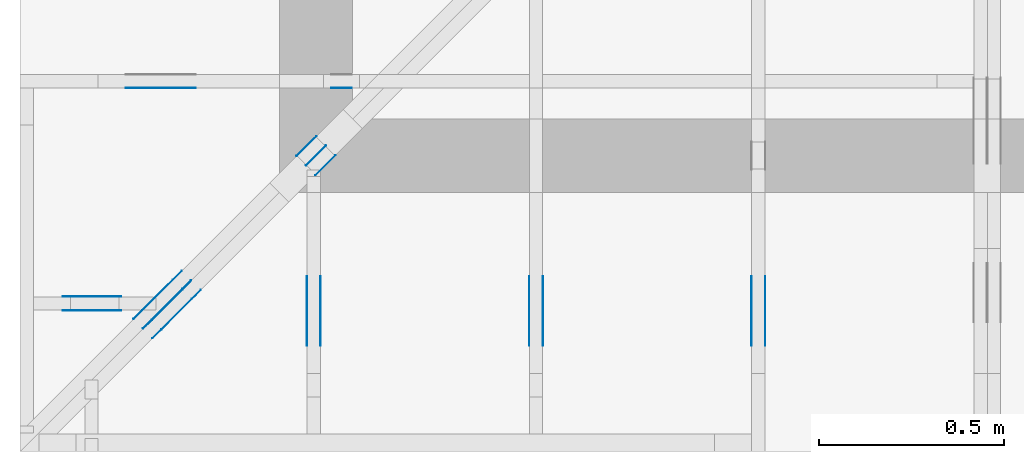
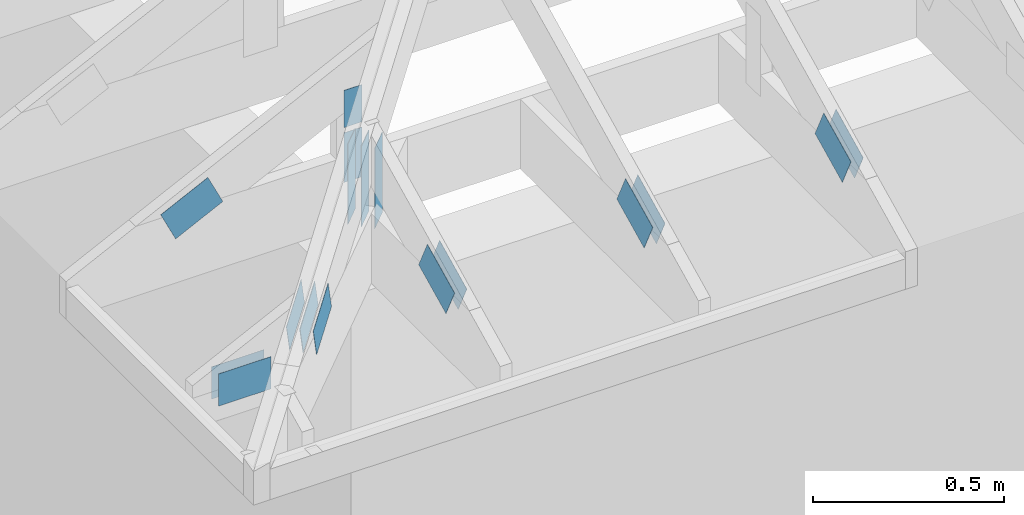
# One storey, part 55 of 159: 19 plates, 6 elements without a shape of their own.
"""IFC2X3 building model written with IfcOpenShell, lengths in millimetres."""

from ifc_helpers import new_model, si_unit, frame, origin, origin_with_axes, origin_2d, place, context, project, spatial, faceted_brep, element, aggregate, save


model = new_model("IFC2X3")

# Units and contexts
model_context = context("Model", 3, precision=1e-05, world=origin())
plan_context = context("Plan", 2, precision=1e-05, world=origin_2d())
ifc_project = project(units=[si_unit("LENGTHUNIT", "METRE", prefix="MILLI"), si_unit("AREAUNIT", "SQUARE_METRE"), si_unit("VOLUMEUNIT", "CUBIC_METRE"), si_unit("SOLIDANGLEUNIT", "STERADIAN"), si_unit("PLANEANGLEUNIT", "RADIAN"), si_unit("MASSUNIT", "GRAM"), si_unit("TIMEUNIT", "SECOND"), si_unit("THERMODYNAMICTEMPERATUREUNIT", "DEGREE_CELSIUS"), si_unit("LUMINOUSINTENSITYUNIT", "LUMEN")], contexts=[model_context, plan_context])

# Site, building, storey
site_placement = place(None, origin_with_axes())
site = spatial("IfcSite", under=ifc_project, at=site_placement, CompositionType="ELEMENT")
building_placement = place(site_placement, origin_with_axes())
building = spatial("IfcBuilding", under=site, at=building_placement, Name="Plan 1", CompositionType="ELEMENT")
storey_placement = place(building_placement, origin_with_axes())
storey = spatial("IfcBuildingStorey", under=building, at=storey_placement, Name="Etasje 1", CompositionType="ELEMENT", Elevation=0.0)

# Assembly, plates
assembly_1_placement = place(storey_placement, frame((-664.0000000000214, -317.99259857873943, 1.1021457184401395e-15), z_axis=(0.0, -1.0, 6.123031769111886e-17), x_axis=(1.0, 0.0, 0.0)))
assembly_1 = element("IfcElementAssembly", 1, at=assembly_1_placement, inside=storey, Name="S9 (106)", AssemblyPlace="FACTORY", PredefinedType="TRUSS")
plate_1_placement = place(assembly_1_placement, frame((237.78413391113284, 148.90464782714844, 0.0), z_axis=(0.0, 0.0, 1.0), x_axis=(-1.0, 1.2246063538223773e-16, 0.0)))
plate_1 = element("IfcPlate", 2, at=plate_1_placement, Name="GNT100S 103x159", context=model_context, shape_type="Brep", body=[
    faceted_brep([(159.0, 103.0, 1.0), (0.0, 103.0, 1.0), (2.842170943040401e-14, 0.0, 1.0), (159.0, 0.0, 1.0), (0.0, 103.0, 0.0), (159.0, 103.0, 1.9471241025775798e-14), (159.0, 2.842170943040401e-14, 1.9471241025775798e-14), (2.842170943040401e-14, 2.842170943040401e-14, 3.4805405954966126e-30), (159.00000085986846, 8.447997602500227e-14, 1.7883454204442307e-30), (159.00000085986846, 8.454120634269339e-14, 1.0), (8.59868492852911e-07, 1.1374806788135708e-13, 1.0), (8.59868492852911e-07, 1.1368683756366597e-13, 9.671333203439804e-39), (159.00000085986846, 103.00000000000011, 0.0), (159.00000085986846, 103.00000000000011, 1.0), (159.00000085986846, 1.1368683772161603e-13, 1.0), (159.00000085986846, 1.1368683772161603e-13, 0.0), (8.598684644312016e-07, 103.00000000000011, 0.0), (8.598684644312016e-07, 103.00000000000011, 1.0), (159.00000085986846, 103.0000000000001, 1.0), (159.00000085986846, 103.0000000000001, -7.888609052210118e-31), (8.59868492852911e-07, 1.1368683772161602e-13, 0.0), (8.598684929141413e-07, 1.1368683772161602e-13, 1.0), (8.598685055275868e-07, 103.00000000000011, 1.0), (8.598685054663564e-07, 103.00000000000011, -2.512595570956075e-30)], [[[0, 1, 2, 3]], [[4, 5, 6, 7]], [[8, 9, 10, 11]], [[12, 13, 14, 15]], [[16, 17, 18, 19]], [[20, 21, 22, 23]]]),
])
plate_2_placement = place(assembly_1_placement, frame((237.78413391113284, 148.90464782714844, -37.0), z_axis=(0.0, 0.0, 1.0), x_axis=(-1.0, 1.2246063538223773e-16, 0.0)))
plate_2 = element("IfcPlate", 3, at=plate_2_placement, Name="GNT100S 103x159", context=model_context, shape_type="Brep", body=[
    faceted_brep([(159.0, 103.0, 1.0), (0.0, 103.0, 1.0), (2.842170943040401e-14, 0.0, 1.0), (159.0, 0.0, 1.0), (0.0, 103.0, 0.0), (159.0, 103.0, 1.9471241025775798e-14), (159.0, 2.842170943040401e-14, 1.9471241025775798e-14), (2.842170943040401e-14, 2.842170943040401e-14, 3.4805405954966126e-30), (159.00000085986846, 8.447997602500227e-14, 1.7883454204442307e-30), (159.00000085986846, 8.454120634269339e-14, 1.0), (8.59868492852911e-07, 1.1374806788135708e-13, 1.0), (8.59868492852911e-07, 1.1368683756366597e-13, 9.671333203439804e-39), (159.00000085986846, 103.00000000000011, 0.0), (159.00000085986846, 103.00000000000011, 1.0), (159.00000085986846, 1.1368683772161603e-13, 1.0), (159.00000085986846, 1.1368683772161603e-13, 0.0), (8.598684644312016e-07, 103.00000000000011, 0.0), (8.598684644312016e-07, 103.00000000000011, 1.0), (159.00000085986846, 103.0000000000001, 1.0), (159.00000085986846, 103.0000000000001, -7.888609052210118e-31), (8.59868492852911e-07, 1.1368683772161602e-13, 0.0), (8.598684929141413e-07, 1.1368683772161602e-13, 1.0), (8.598685055275868e-07, 103.00000000000011, 1.0), (8.598685054663564e-07, 103.00000000000011, -2.512595570956075e-30)], [[[0, 1, 2, 3]], [[4, 5, 6, 7]], [[8, 9, 10, 11]], [[12, 13, 14, 15]], [[16, 17, 18, 19]], [[20, 21, 22, 23]]]),
])
aggregate(assembly_1, [plate_1, plate_2])

assembly_2_placement = place(storey_placement, frame((111.02226140474966, -663.9989301294845, 1.1021457184401395e-15), z_axis=(1.0, -6.123031769111886e-17, 6.123031769111886e-17), x_axis=(6.123031769111886e-17, 1.0, 0.0)))
assembly_2 = element("IfcElementAssembly", 4, at=assembly_2_placement, inside=storey, Name="S10 (29)", AssemblyPlace="FACTORY", PredefinedType="TRUSS")
plate_3_placement = place(assembly_2_placement, frame((295.11001552729493, 141.8615890385072, 0.0), z_axis=(0.0, 0.0, 1.0), x_axis=(0.8987940462991671, 0.43837114678907757, 0.0)))
plate_3 = element("IfcPlate", 5, at=plate_3_placement, Name="GNT100S 103x159", context=model_context, shape_type="Brep", body=[
    faceted_brep([(158.9999923478332, 103.000019338307, 1.0), (0.0, 103.000019338307, 1.0), (6.332527050290082e-06, 1.2203795577647725e-05, 1.0), (159.00001239486903, 1.2203795577647725e-05, 1.0), (0.0, 103.000019338307, 0.0), (158.9999923478332, 103.000019338307, 1.947124008868659e-14), (159.00001239486903, 0.0, 1.9471242543659335e-14), (6.332527050290082e-06, 0.0, 7.754852861537311e-22), (159.00000316306603, 1.1149113929956653e-05, 3.5286157753774464e-30), (159.00000316306603, 1.1149113930017883e-05, 1.0), (3.1630660259907017e-06, 1.1149113959224745e-05, 1.0), (3.1630660259907017e-06, 1.1149113959163515e-05, 0.0), (159.00000316306603, 103.00001114911396, 3.1554436208840472e-30), (159.00000316306603, 103.00001114911396, 1.0), (159.00000316306603, 1.1149113987585224e-05, 1.0), (159.00000316306603, 1.1149113987585224e-05, 0.0), (3.1630660259907013e-06, 103.00001114911397, 0.0), (3.1630660259907013e-06, 103.00001114911397, 1.0), (159.00000316306597, 103.00001114911396, 1.0), (159.00000316306597, 103.00001114911396, 0.0), (3.163066025990703e-06, 1.1149113959163515e-05, -9.4039548065783e-38), (3.1630660260519333e-06, 1.1149113959163515e-05, 1.0), (3.1630660386653788e-06, 103.00001114911397, 1.0), (3.1630660386041485e-06, 103.00001114911397, -7.723253437374298e-31)], [[[0, 1, 2, 3]], [[4, 5, 6, 7]], [[8, 9, 10, 11]], [[12, 13, 14, 15]], [[16, 17, 18, 19]], [[20, 21, 22, 23]]]),
])
plate_4_placement = place(assembly_2_placement, frame((295.11001552729493, 141.8615890385072, -37.0), z_axis=(0.0, 0.0, 1.0), x_axis=(0.8987940462991671, 0.43837114678907757, 0.0)))
plate_4 = element("IfcPlate", 6, at=plate_4_placement, Name="GNT100S 103x159", context=model_context, shape_type="Brep", body=[
    faceted_brep([(158.9999923478332, 103.000019338307, 1.0), (0.0, 103.000019338307, 1.0), (6.332527050290082e-06, 1.2203795577647725e-05, 1.0), (159.00001239486903, 1.2203795577647725e-05, 1.0), (0.0, 103.000019338307, 0.0), (158.9999923478332, 103.000019338307, 1.947124008868659e-14), (159.00001239486903, 0.0, 1.9471242543659335e-14), (6.332527050290082e-06, 0.0, 7.754852861537311e-22), (159.00000316306603, 1.1149113929956653e-05, 3.5286157753774464e-30), (159.00000316306603, 1.1149113930017883e-05, 1.0), (3.1630660259907017e-06, 1.1149113959224745e-05, 1.0), (3.1630660259907017e-06, 1.1149113959163515e-05, 0.0), (159.00000316306603, 103.00001114911396, 3.1554436208840472e-30), (159.00000316306603, 103.00001114911396, 1.0), (159.00000316306603, 1.1149113987585224e-05, 1.0), (159.00000316306603, 1.1149113987585224e-05, 0.0), (3.1630660259907013e-06, 103.00001114911397, 0.0), (3.1630660259907013e-06, 103.00001114911397, 1.0), (159.00000316306597, 103.00001114911396, 1.0), (159.00000316306597, 103.00001114911396, 0.0), (3.163066025990703e-06, 1.1149113959163515e-05, -9.4039548065783e-38), (3.1630660260519333e-06, 1.1149113959163515e-05, 1.0), (3.1630660386653788e-06, 103.00001114911397, 1.0), (3.1630660386041485e-06, 103.00001114911397, -7.723253437374298e-31)], [[[0, 1, 2, 3]], [[4, 5, 6, 7]], [[8, 9, 10, 11]], [[12, 13, 14, 15]], [[16, 17, 18, 19]], [[20, 21, 22, 23]]]),
])
aggregate(assembly_2, [plate_3, plate_4])

assembly_3_placement = place(storey_placement, frame((711.0222614047476, -663.9989301294845, 1.1021457184401395e-15), z_axis=(1.0, 1.6081428723391245e-16, 6.123031769111886e-17), x_axis=(-1.6081428723391245e-16, 1.0, 0.0)))
assembly_3 = element("IfcElementAssembly", 7, at=assembly_3_placement, inside=storey, Name="S11 (28)", AssemblyPlace="FACTORY", PredefinedType="TRUSS")
plate_5_placement = place(assembly_3_placement, frame((295.1100155272948, 141.8615890385072, 0.0), z_axis=(0.0, 0.0, 1.0), x_axis=(0.898794046299167, 0.4383711467890774, 0.0)))
plate_5 = element("IfcPlate", 8, at=plate_5_placement, Name="GNT100S 103x159", context=model_context, shape_type="Brep", body=[
    faceted_brep([(158.9999923478332, 103.00001933830698, 1.0), (0.0, 103.00001933830698, 1.0), (6.332527107133501e-06, 1.220379553501516e-05, 1.0), (159.00001239486903, 1.220379553501516e-05, 1.0), (0.0, 103.00001933830698, 0.0), (158.9999923478332, 103.00001933830698, 1.947124008868659e-14), (159.00001239486903, 0.0, 1.9471242543659335e-14), (6.332527107133501e-06, 0.0, 7.754852931148123e-22), (159.00000316306608, 1.1149113972589217e-05, 2.6584806265032933e-30), (159.00000316306608, 1.1149113972650448e-05, 1.0), (3.1630660259907017e-06, 1.1149114001857309e-05, 1.0), (3.1630660259907017e-06, 1.1149114001796079e-05, 0.0), (159.00000316306608, 103.00001114911404, 3.1554436208840472e-30), (159.00000316306608, 103.00001114911404, 1.0), (159.00000316306608, 1.1149114016006934e-05, 1.0), (159.00000316306608, 1.1149114016006934e-05, 0.0), (3.1630660828341206e-06, 103.00001114911402, 0.0), (3.1630660828341206e-06, 103.00001114911402, 1.0), (159.00000316306603, 103.00001114911404, 1.0), (159.00000316306603, 103.00001114911404, 0.0), (3.1630660259907017e-06, 1.1149114001796079e-05, 2.350988701644575e-38), (3.163066026051932e-06, 1.1149114001796079e-05, 1.0), (3.163066084406566e-06, 103.00001114911402, 1.0), (3.163066084345336e-06, 103.00001114911402, -9.253216463994955e-32)], [[[0, 1, 2, 3]], [[4, 5, 6, 7]], [[8, 9, 10, 11]], [[12, 13, 14, 15]], [[16, 17, 18, 19]], [[20, 21, 22, 23]]]),
])
plate_6_placement = place(assembly_3_placement, frame((295.1100155272948, 141.8615890385072, -37.00000000000001), z_axis=(0.0, 0.0, 1.0), x_axis=(0.898794046299167, 0.4383711467890774, 0.0)))
plate_6 = element("IfcPlate", 9, at=plate_6_placement, Name="GNT100S 103x159", context=model_context, shape_type="Brep", body=[
    faceted_brep([(158.9999923478332, 103.00001933830698, 1.0), (0.0, 103.00001933830698, 1.0), (6.332527107133501e-06, 1.220379553501516e-05, 1.0), (159.00001239486903, 1.220379553501516e-05, 1.0), (0.0, 103.00001933830698, 0.0), (158.9999923478332, 103.00001933830698, 1.947124008868659e-14), (159.00001239486903, 0.0, 1.9471242543659335e-14), (6.332527107133501e-06, 0.0, 7.754852931148123e-22), (159.00000316306608, 1.1149113972589217e-05, 2.6584806265032933e-30), (159.00000316306608, 1.1149113972650448e-05, 1.0), (3.1630660259907017e-06, 1.1149114001857309e-05, 1.0), (3.1630660259907017e-06, 1.1149114001796079e-05, 0.0), (159.00000316306608, 103.00001114911404, 3.1554436208840472e-30), (159.00000316306608, 103.00001114911404, 1.0), (159.00000316306608, 1.1149114016006934e-05, 1.0), (159.00000316306608, 1.1149114016006934e-05, 0.0), (3.1630660828341206e-06, 103.00001114911402, 0.0), (3.1630660828341206e-06, 103.00001114911402, 1.0), (159.00000316306603, 103.00001114911404, 1.0), (159.00000316306603, 103.00001114911404, 0.0), (3.1630660259907017e-06, 1.1149114001796079e-05, 2.350988701644575e-38), (3.163066026051932e-06, 1.1149114001796079e-05, 1.0), (3.163066084406566e-06, 103.00001114911402, 1.0), (3.163066084345336e-06, 103.00001114911402, -9.253216463994955e-32)], [[[0, 1, 2, 3]], [[4, 5, 6, 7]], [[8, 9, 10, 11]], [[12, 13, 14, 15]], [[16, 17, 18, 19]], [[20, 21, 22, 23]]]),
])
aggregate(assembly_3, [plate_5, plate_6])

assembly_4_placement = place(storey_placement, frame((1311.0222614047498, -699.9989301294839, 1.1021457184401395e-15), z_axis=(1.0, -6.123031769111886e-17, 6.123031769111886e-17), x_axis=(6.123031769111886e-17, 1.0, 0.0)))
assembly_4 = element("IfcElementAssembly", 10, at=assembly_4_placement, inside=storey, Name="S12 (27)", AssemblyPlace="FACTORY", PredefinedType="TRUSS")
plate_7_placement = place(assembly_4_placement, frame((331.1100183709921, 141.861590425471, 0.0), z_axis=(0.0, 0.0, 1.0), x_axis=(0.898794046299167, 0.4383711467890774, 0.0)))
plate_7 = element("IfcPlate", 11, at=plate_7_placement, Name="GNT100S 103x159", context=model_context, shape_type="Brep", body=[
    faceted_brep([(158.9999891839301, 103.00001264929412, 1.0), (1.0550605679782166e-05, 103.00001264929412, 1.0), (3.168624004956655e-06, 1.220379553501516e-05, 1.0), (159.00000923096593, 1.220379553501516e-05, 1.0), (1.0550605679782166e-05, 103.00001264929412, 1.2920338752135702e-21), (158.9999891839301, 103.00001264929412, 1.9471239701233004e-14), (159.00000923096593, 0.0, 1.947124215620575e-14), (3.168624004956655e-06, 0.0, 3.8803170893440275e-22), (159.0, 1.1148705751576668e-05, -8.220600630328674e-31), (159.0, 1.1148705751637899e-05, 1.0), (5.684341886080802e-14, 1.114870578084476e-05, 1.0), (5.684341886080802e-14, 1.114870578078353e-05, 0.0), (159.0, 103.0000111487058, 0.0), (159.0, 103.0000111487058, 1.0), (159.0, 1.1148705738150966e-05, 1.0), (159.0, 1.1148705738150966e-05, 0.0), (0.0, 103.00001114870578, 0.0), (0.0, 103.00001114870578, 1.0), (159.00000000000003, 103.00001114870581, 1.0), (159.00000000000003, 103.00001114870581, 7.888609052210118e-31), (5.684342142778948e-14, 1.114870578078353e-05, -1.5717708996585246e-37), (5.69046517454806e-14, 1.114870578078353e-05, 1.0), (2.3776908575294633e-14, 103.00001114870578, 1.0), (2.3715678257603514e-14, 103.00001114870578, -1.4521185139734233e-30)], [[[0, 1, 2, 3]], [[4, 5, 6, 7]], [[8, 9, 10, 11]], [[12, 13, 14, 15]], [[16, 17, 18, 19]], [[20, 21, 22, 23]]]),
])
plate_8_placement = place(assembly_4_placement, frame((331.1100183709921, 141.861590425471, -37.00000000000001), z_axis=(0.0, 0.0, 1.0), x_axis=(0.898794046299167, 0.4383711467890774, 0.0)))
plate_8 = element("IfcPlate", 12, at=plate_8_placement, Name="GNT100S 103x159", context=model_context, shape_type="Brep", body=[
    faceted_brep([(158.9999891839301, 103.00001264929412, 1.0), (1.0550605679782166e-05, 103.00001264929412, 1.0), (3.168624004956655e-06, 1.220379553501516e-05, 1.0), (159.00000923096593, 1.220379553501516e-05, 1.0), (1.0550605679782166e-05, 103.00001264929412, 1.2920338752135702e-21), (158.9999891839301, 103.00001264929412, 1.9471239701233004e-14), (159.00000923096593, 0.0, 1.947124215620575e-14), (3.168624004956655e-06, 0.0, 3.8803170893440275e-22), (159.0, 1.1148705751576668e-05, -8.220600630328674e-31), (159.0, 1.1148705751637899e-05, 1.0), (5.684341886080802e-14, 1.114870578084476e-05, 1.0), (5.684341886080802e-14, 1.114870578078353e-05, 0.0), (159.0, 103.0000111487058, 0.0), (159.0, 103.0000111487058, 1.0), (159.0, 1.1148705738150966e-05, 1.0), (159.0, 1.1148705738150966e-05, 0.0), (0.0, 103.00001114870578, 0.0), (0.0, 103.00001114870578, 1.0), (159.00000000000003, 103.00001114870581, 1.0), (159.00000000000003, 103.00001114870581, 7.888609052210118e-31), (5.684342142778948e-14, 1.114870578078353e-05, -1.5717708996585246e-37), (5.69046517454806e-14, 1.114870578078353e-05, 1.0), (2.3776908575294633e-14, 103.00001114870578, 1.0), (2.3715678257603514e-14, 103.00001114870578, -1.4521185139734233e-30)], [[[0, 1, 2, 3]], [[4, 5, 6, 7]], [[8, 9, 10, 11]], [[12, 13, 14, 15]], [[16, 17, 18, 19]], [[20, 21, 22, 23]]]),
])
aggregate(assembly_4, [plate_7, plate_8])

assembly_5_placement = place(storey_placement, frame((-700.000000000007, 282.0074014212605, 1.1021457184401395e-15), z_axis=(0.0, -1.0, 6.123031769111886e-17), x_axis=(1.0, 0.0, 0.0)))
assembly_5 = element("IfcElementAssembly", 13, at=assembly_5_placement, inside=storey, Name="S8 (22)", AssemblyPlace="FACTORY", PredefinedType="TRUSS")
plate_9_placement = place(assembly_5_placement, frame((331.1100183702398, 141.86159042510408, 0.0), z_axis=(0.0, 0.0, 1.0), x_axis=(0.898794046299167, 0.4383711467890774, 0.0)))
plate_9 = element("IfcPlate", 14, at=plate_9_placement, Name="GNT100S 103x159", context=model_context, shape_type="Brep", body=[
    faceted_brep([(158.99998918476712, 103.00001264929412, 1.0), (1.0551442699124891e-05, 103.00001264929412, 1.0), (3.1694610242993804e-06, 1.220379553501516e-05, 1.0), (159.00000923180295, 1.220379553501516e-05, 1.0), (1.0551442699124891e-05, 103.00001264929412, 1.2921363771341076e-21), (158.99998918476712, 103.00001264929412, 1.947123970133551e-14), (159.00000923180295, 0.0, 1.9471242156308252e-14), (3.1694610242993804e-06, 0.0, 3.8813421085494012e-22), (159.00000000000006, 1.1149114128908619e-05, 4.8075085841285717e-32), (159.00000000000006, 1.114911412896985e-05, 1.0), (5.684341886080801e-14, 1.1149114158176711e-05, 1.0), (5.684341886080801e-14, 1.114911415811548e-05, 0.0), (159.00000000000006, 103.00001114911416, 0.0), (159.00000000000006, 103.00001114911416, 1.0), (159.00000000000006, 1.1149114129693771e-05, 1.0), (159.00000000000006, 1.1149114129693771e-05, 0.0), (0.0, 103.00001114911416, 0.0), (-3.7491518045553436e-33, 103.00001114911416, 1.0), (159.00000000000006, 103.00001114911414, 1.0), (159.00000000000006, 103.00001114911414, -7.888609052210118e-31), (5.68434214278835e-14, 1.114911415811548e-05, -1.5718284790124237e-37), (5.690465174557462e-14, 1.114911415811548e-05, 1.0), (2.3776908575388665e-14, 103.00001114911416, 1.0), (2.3715678257697546e-14, 103.00001114911416, -1.4521185139791808e-30)], [[[0, 1, 2, 3]], [[4, 5, 6, 7]], [[8, 9, 10, 11]], [[12, 13, 14, 15]], [[16, 17, 18, 19]], [[20, 21, 22, 23]]]),
])
plate_10_placement = place(assembly_5_placement, frame((840.5946433071217, 438.23297119140625, 0.0), z_axis=(0.0, 0.0, 1.0), x_axis=(6.123031769111886e-17, -1.0, 0.0)))
plate_10 = element("IfcPlate", 15, at=plate_10_placement, Name="GNT100S 55x119", context=model_context, shape_type="Brep", body=[
    faceted_brep([(119.0, 55.000022220222036, 1.0), (0.0, 55.000022220222036, 1.0), (0.0, 2.2220222035684856e-05, 1.0), (119.0, 2.2220222035684856e-05, 1.0), (0.0, 55.000022220222036, 0.0), (119.0, 55.000022220222036, 1.457281561048629e-14), (119.0, 2.2220222035684856e-05, 1.457281561048629e-14), (0.0, 2.2220222035684856e-05, 0.0), (119.00001088225764, -2.1859225414701712e-14, 1.3384473166239653e-30), (119.00001088225764, -2.1797995097010593e-14, 1.0), (1.088225764078743e-05, 6.122831871884123e-17, 1.0), (1.088225764078743e-05, -1.99897227762606e-21, 1.223977076147831e-37), (119.00001088225764, 55.0, 0.0), (119.00001088225764, 55.0, 1.0), (119.00001088225764, 0.0, 1.0), (119.00001088225764, 0.0, 0.0), (1.088225764078743e-05, 55.0, 0.0), (1.088225764078743e-05, 55.0, 1.0), (119.00001088225764, 54.99999999999999, 1.0), (119.00001088225764, 54.99999999999999, -3.944304526105059e-31), (1.088225764078743e-05, 0.0, 0.0), (1.088225764084866e-05, -7.498303609110687e-33, 1.0), (1.0882257647583995e-05, 55.0, 1.0), (1.0882257647522764e-05, 55.0, -4.124066764605687e-31)], [[[0, 1, 2, 3]], [[4, 5, 6, 7]], [[8, 9, 10, 11]], [[12, 13, 14, 15]], [[16, 17, 18, 19]], [[20, 21, 22, 23]]]),
])
plate_11_placement = place(assembly_5_placement, frame((895.5946655273438, 143.5, 0.0), z_axis=(0.0, 0.0, 1.0), x_axis=(6.123031769111886e-17, 1.0, 0.0)))
plate_11 = element("IfcPlate", 16, at=plate_11_placement, Name="GNT100S 55x159", context=model_context, shape_type="Brep", body=[
    faceted_brep([(159.0, 55.0, 1.0), (0.0, 55.0, 1.0), (0.0, 0.0, 1.0), (159.0, 0.0, 1.0), (0.0, 55.0, 0.0), (159.0, 55.0, 1.9471241025775798e-14), (159.0, 0.0, 1.9471241025775798e-14), (0.0, 0.0, 0.0), (159.00000000069178, 2.22201997238578e-05, 1.788345383589592e-30), (159.00000000069178, 2.222019972391903e-05, 1.0), (6.918128292454639e-10, 2.2220199753125893e-05, 1.0), (6.918128292454639e-10, 2.2220199753064662e-05, 0.0), (159.00000000069178, 55.00002222019975, 0.0), (159.00000000069178, 55.00002222019975, 1.0), (159.00000000069178, 2.2220199753064662e-05, 1.0), (159.00000000069178, 2.2220199753064662e-05, 0.0), (6.918128292454639e-10, 55.00002222019975, 0.0), (6.918128292454639e-10, 55.00002222019975, 1.0), (159.00000000069178, 55.000022220199746, 1.0), (159.00000000069178, 55.000022220199746, -7.888609052210118e-31), (6.918128292481851e-10, 2.2220199753064662e-05, -1.6661254890463556e-37), (6.918128904785028e-10, 2.2220199753064662e-05, 1.0), (6.918196258134488e-10, 55.00002222019975, 1.0), (6.918195645831311e-10, 55.00002222019975, -4.124068651136367e-31)], [[[0, 1, 2, 3]], [[4, 5, 6, 7]], [[8, 9, 10, 11]], [[12, 13, 14, 15]], [[16, 17, 18, 19]], [[20, 21, 22, 23]]]),
])
aggregate(assembly_5, [plate_9, plate_10, plate_11])

assembly_6_placement = place(storey_placement, frame((-674.5441558772914, -725.4547742521996, 2.204291436880279e-15), z_axis=(0.7071067811865475, -0.7071067811865476, 6.123031769111886e-17), x_axis=(0.7071067811865476, 0.7071067811865475, 0.0)))
assembly_6 = element("IfcElementAssembly", 17, at=assembly_6_placement, inside=storey, Name="GR1 (8)", AssemblyPlace="FACTORY", PredefinedType="TRUSS")
plate_12_placement = place(assembly_6_placement, frame((503.2603454589843, 148.39434814453122, 0.0), z_axis=(0.0, 0.0, 1.0), x_axis=(0.9453579955214152, 0.32603413978252627, 0.0)))
plate_12 = element("IfcPlate", 18, at=plate_12_placement, Name="GNT100S 103x159", context=model_context, shape_type="Brep", body=[
    faceted_brep([(158.99997445489055, 102.99999720977215, 1.0), (3.2122421771418885e-06, 102.99999720977215, 1.0), (0.0, 0.0, 1.0), (159.0000000926849, 0.0, 1.0), (3.2122421771418885e-06, 102.99999720977215, 3.933732180144183e-22), (158.99997445489055, 102.99999720977215, 1.9471237897505463e-14), (159.0000000926849, 3.709764143877692e-06, 1.947124103712605e-14), (0.0, 3.709764143877692e-06, 0.0), (159.00000083894315, 7.403347971255388e-07, 3.5286157224802006e-30), (159.00000083894315, 7.403347971867691e-07, 1.0), (8.389431513933233e-07, 7.403348263936307e-07, 1.0), (8.389431513933233e-07, 7.403348263324003e-07, 1.7632415262334313e-38), (159.00000083894315, 103.0000007403348, 0.0), (159.00000083894315, 103.0000007403348, 1.0), (159.00000083894315, 7.4033485475411e-07, 1.0), (159.00000083894315, 7.4033485475411e-07, 0.0), (8.389431513933232e-07, 103.00000074033483, 0.0), (8.389431513933232e-07, 103.00000074033483, 1.0), (159.00000083894315, 103.00000074033478, 1.0), (159.00000083894315, 103.00000074033478, -7.888609052210118e-31), (8.389431513933233e-07, 7.403348263324006e-07, -5.877471754111438e-39), (8.389431514545536e-07, 7.403348263324006e-07, 1.0), (8.389431640679991e-07, 103.00000074033483, 1.0), (8.389431640067688e-07, 103.00000074033483, -7.723252790852405e-31)], [[[0, 1, 2, 3]], [[4, 5, 6, 7]], [[8, 9, 10, 11]], [[12, 13, 14, 15]], [[16, 17, 18, 19]], [[20, 21, 22, 23]]]),
])
plate_13_placement = place(assembly_6_placement, frame((503.2603454589843, 148.39434814453122, -36.99999999999999), z_axis=(0.0, 0.0, 1.0), x_axis=(0.9453579955214152, 0.32603413978252627, 0.0)))
plate_13 = element("IfcPlate", 19, at=plate_13_placement, Name="GNT100S 103x159", context=model_context, shape_type="Brep", body=[
    faceted_brep([(158.99997445489055, 102.99999720977215, 1.0), (3.2122421771418885e-06, 102.99999720977215, 1.0), (0.0, 0.0, 1.0), (159.0000000926849, 0.0, 1.0), (3.2122421771418885e-06, 102.99999720977215, 3.933732180144183e-22), (158.99997445489055, 102.99999720977215, 1.9471237897505463e-14), (159.0000000926849, 3.709764143877692e-06, 1.947124103712605e-14), (0.0, 3.709764143877692e-06, 0.0), (159.00000083894315, 7.403347971255388e-07, 3.5286157224802006e-30), (159.00000083894315, 7.403347971867691e-07, 1.0), (8.389431513933233e-07, 7.403348263936307e-07, 1.0), (8.389431513933233e-07, 7.403348263324003e-07, 1.7632415262334313e-38), (159.00000083894315, 103.0000007403348, 0.0), (159.00000083894315, 103.0000007403348, 1.0), (159.00000083894315, 7.4033485475411e-07, 1.0), (159.00000083894315, 7.4033485475411e-07, 0.0), (8.389431513933232e-07, 103.00000074033483, 0.0), (8.389431513933232e-07, 103.00000074033483, 1.0), (159.00000083894315, 103.00000074033478, 1.0), (159.00000083894315, 103.00000074033478, -7.888609052210118e-31), (8.389431513933233e-07, 7.403348263324006e-07, -5.877471754111438e-39), (8.389431514545536e-07, 7.403348263324006e-07, 1.0), (8.389431640679991e-07, 103.00000074033483, 1.0), (8.389431640067688e-07, 103.00000074033483, -7.723252790852405e-31)], [[[0, 1, 2, 3]], [[4, 5, 6, 7]], [[8, 9, 10, 11]], [[12, 13, 14, 15]], [[16, 17, 18, 19]], [[20, 21, 22, 23]]]),
])
plate_14_placement = place(assembly_6_placement, frame((503.2603454589843, 148.39434814453122, -35.99999999999999), z_axis=(0.0, 0.0, 1.0), x_axis=(0.9453579955214152, 0.32603413978252627, 0.0)))
plate_14 = element("IfcPlate", 20, at=plate_14_placement, Name="GNT100S 103x159", context=model_context, shape_type="Brep", body=[
    faceted_brep([(158.99997445489055, 102.99999720977215, 1.0), (3.2122421771418885e-06, 102.99999720977215, 1.0), (0.0, 0.0, 1.0), (159.0000000926849, 0.0, 1.0), (3.2122421771418885e-06, 102.99999720977215, 3.933732180144183e-22), (158.99997445489055, 102.99999720977215, 1.9471237897505463e-14), (159.0000000926849, 3.709764143877692e-06, 1.947124103712605e-14), (0.0, 3.709764143877692e-06, 0.0), (159.00000083894315, 7.403347971255388e-07, 3.5286157224802006e-30), (159.00000083894315, 7.403347971867691e-07, 1.0), (8.389431513933233e-07, 7.403348263936307e-07, 1.0), (8.389431513933233e-07, 7.403348263324003e-07, 1.7632415262334313e-38), (159.00000083894315, 103.0000007403348, 0.0), (159.00000083894315, 103.0000007403348, 1.0), (159.00000083894315, 7.4033485475411e-07, 1.0), (159.00000083894315, 7.4033485475411e-07, 0.0), (8.389431513933232e-07, 103.00000074033483, 0.0), (8.389431513933232e-07, 103.00000074033483, 1.0), (159.00000083894315, 103.00000074033478, 1.0), (159.00000083894315, 103.00000074033478, -7.888609052210118e-31), (8.389431513933233e-07, 7.403348263324006e-07, -5.877471754111438e-39), (8.389431514545536e-07, 7.403348263324006e-07, 1.0), (8.389431640679991e-07, 103.00000074033483, 1.0), (8.389431640067688e-07, 103.00000074033483, -7.723252790852405e-31)], [[[0, 1, 2, 3]], [[4, 5, 6, 7]], [[8, 9, 10, 11]], [[12, 13, 14, 15]], [[16, 17, 18, 19]], [[20, 21, 22, 23]]]),
])
plate_15_placement = place(assembly_6_placement, frame((503.2603454589843, 148.39434814453122, -73.0), z_axis=(0.0, 0.0, 1.0), x_axis=(0.9453579955214152, 0.32603413978252627, 0.0)))
plate_15 = element("IfcPlate", 21, at=plate_15_placement, Name="GNT100S 103x159", context=model_context, shape_type="Brep", body=[
    faceted_brep([(158.99997445489055, 102.99999720977215, 1.0), (3.2122421771418885e-06, 102.99999720977215, 1.0), (0.0, 0.0, 1.0), (159.0000000926849, 0.0, 1.0), (3.2122421771418885e-06, 102.99999720977215, 3.933732180144183e-22), (158.99997445489055, 102.99999720977215, 1.9471237897505463e-14), (159.0000000926849, 3.709764143877692e-06, 1.947124103712605e-14), (0.0, 3.709764143877692e-06, 0.0), (159.00000083894315, 7.403347971255388e-07, 3.5286157224802006e-30), (159.00000083894315, 7.403347971867691e-07, 1.0), (8.389431513933233e-07, 7.403348263936307e-07, 1.0), (8.389431513933233e-07, 7.403348263324003e-07, 1.7632415262334313e-38), (159.00000083894315, 103.0000007403348, 0.0), (159.00000083894315, 103.0000007403348, 1.0), (159.00000083894315, 7.4033485475411e-07, 1.0), (159.00000083894315, 7.4033485475411e-07, 0.0), (8.389431513933232e-07, 103.00000074033483, 0.0), (8.389431513933232e-07, 103.00000074033483, 1.0), (159.00000083894315, 103.00000074033478, 1.0), (159.00000083894315, 103.00000074033478, -7.888609052210118e-31), (8.389431513933233e-07, 7.403348263324006e-07, -5.877471754111438e-39), (8.389431514545536e-07, 7.403348263324006e-07, 1.0), (8.389431640679991e-07, 103.00000074033483, 1.0), (8.389431640067688e-07, 103.00000074033483, -7.723252790852405e-31)], [[[0, 1, 2, 3]], [[4, 5, 6, 7]], [[8, 9, 10, 11]], [[12, 13, 14, 15]], [[16, 17, 18, 19]], [[20, 21, 22, 23]]]),
])
plate_16_placement = place(assembly_6_placement, frame((1091.9566363361005, 410.8641357421875, 0.0), z_axis=(0.0, 0.0, 1.0), x_axis=(6.123031769111886e-17, -1.0, 0.0)))
plate_16 = element("IfcPlate", 22, at=plate_16_placement, Name="GNT100S 76x258", context=model_context, shape_type="Brep", body=[
    faceted_brep([(258.00001525878906, 76.00002870296203, 1.0), (0.0, 76.00002870296203, 1.0), (0.0, 2.870296202672762e-05, 1.0), (258.00001525878906, 2.870296202672762e-05, 1.0), (0.0, 76.00002870296203, 0.0), (258.00001525878906, 76.00002870296203, 3.159484579721834e-14), (258.00001525878906, 2.870296202672762e-05, 3.159484579721834e-14), (0.0, 2.870296202672762e-05, 0.0), (258.00001343312294, -4.7392268360469154e-14, 2.9018436478142872e-30), (258.00001343312294, -4.7331038042778035e-14, 1.0), (1.343312294466159e-05, 6.12278501479624e-17, 1.0), (1.343312294466159e-05, -2.467543156456462e-21, 1.5108845138637538e-37), (258.00001343312294, 76.0, 0.0), (258.00001343312294, 76.0, 1.0), (258.00001343312294, 0.0, 1.0), (258.00001343312294, 0.0, 0.0), (1.343312294466159e-05, 76.0, 0.0), (1.343312294466159e-05, 76.0, 1.0), (258.00001343312294, 75.99999999999999, 1.0), (258.00001343312294, 75.99999999999999, -7.888609052210118e-31), (1.343312294466159e-05, 0.0, 0.0), (1.3433122944722821e-05, -7.498303609110687e-33, 1.0), (1.343312295402983e-05, 76.0, 1.0), (1.3433122953968599e-05, 76.0, -5.69871103679771e-31)], [[[0, 1, 2, 3]], [[4, 5, 6, 7]], [[8, 9, 10, 11]], [[12, 13, 14, 15]], [[16, 17, 18, 19]], [[20, 21, 22, 23]]]),
])
plate_17_placement = place(assembly_6_placement, frame((1091.9566363361005, 410.8641357421875, -37.0), z_axis=(0.0, 0.0, 1.0), x_axis=(6.123031769111886e-17, -1.0, 0.0)))
plate_17 = element("IfcPlate", 23, at=plate_17_placement, Name="GNT100S 76x258", context=model_context, shape_type="Brep", body=[
    faceted_brep([(258.00001525878906, 76.00002870296203, 1.0), (0.0, 76.00002870296203, 1.0), (0.0, 2.870296202672762e-05, 1.0), (258.00001525878906, 2.870296202672762e-05, 1.0), (0.0, 76.00002870296203, 0.0), (258.00001525878906, 76.00002870296203, 3.159484579721834e-14), (258.00001525878906, 2.870296202672762e-05, 3.159484579721834e-14), (0.0, 2.870296202672762e-05, 0.0), (258.00001343312294, -4.7392268360469154e-14, 2.9018436478142872e-30), (258.00001343312294, -4.7331038042778035e-14, 1.0), (1.343312294466159e-05, 6.12278501479624e-17, 1.0), (1.343312294466159e-05, -2.467543156456462e-21, 1.5108845138637538e-37), (258.00001343312294, 76.0, 0.0), (258.00001343312294, 76.0, 1.0), (258.00001343312294, 0.0, 1.0), (258.00001343312294, 0.0, 0.0), (1.343312294466159e-05, 76.0, 0.0), (1.343312294466159e-05, 76.0, 1.0), (258.00001343312294, 75.99999999999999, 1.0), (258.00001343312294, 75.99999999999999, -7.888609052210118e-31), (1.343312294466159e-05, 0.0, 0.0), (1.3433122944722821e-05, -7.498303609110687e-33, 1.0), (1.343312295402983e-05, 76.0, 1.0), (1.3433122953968599e-05, 76.0, -5.69871103679771e-31)], [[[0, 1, 2, 3]], [[4, 5, 6, 7]], [[8, 9, 10, 11]], [[12, 13, 14, 15]], [[16, 17, 18, 19]], [[20, 21, 22, 23]]]),
])
plate_18_placement = place(assembly_6_placement, frame((1091.9566363361005, 410.8641357421875, -36.0), z_axis=(0.0, 0.0, 1.0), x_axis=(6.123031769111886e-17, -1.0, 0.0)))
plate_18 = element("IfcPlate", 24, at=plate_18_placement, Name="GNT100S 76x258", context=model_context, shape_type="Brep", body=[
    faceted_brep([(258.00001525878906, 76.00002870296203, 1.0), (0.0, 76.00002870296203, 1.0), (0.0, 2.870296202672762e-05, 1.0), (258.00001525878906, 2.870296202672762e-05, 1.0), (0.0, 76.00002870296203, 0.0), (258.00001525878906, 76.00002870296203, 3.159484579721834e-14), (258.00001525878906, 2.870296202672762e-05, 3.159484579721834e-14), (0.0, 2.870296202672762e-05, 0.0), (258.00001343312294, -4.7392268360469154e-14, 2.9018436478142872e-30), (258.00001343312294, -4.7331038042778035e-14, 1.0), (1.343312294466159e-05, 6.12278501479624e-17, 1.0), (1.343312294466159e-05, -2.467543156456462e-21, 1.5108845138637538e-37), (258.00001343312294, 76.0, 0.0), (258.00001343312294, 76.0, 1.0), (258.00001343312294, 0.0, 1.0), (258.00001343312294, 0.0, 0.0), (1.343312294466159e-05, 76.0, 0.0), (1.343312294466159e-05, 76.0, 1.0), (258.00001343312294, 75.99999999999999, 1.0), (258.00001343312294, 75.99999999999999, -7.888609052210118e-31), (1.343312294466159e-05, 0.0, 0.0), (1.3433122944722821e-05, -7.498303609110687e-33, 1.0), (1.343312295402983e-05, 76.0, 1.0), (1.3433122953968599e-05, 76.0, -5.69871103679771e-31)], [[[0, 1, 2, 3]], [[4, 5, 6, 7]], [[8, 9, 10, 11]], [[12, 13, 14, 15]], [[16, 17, 18, 19]], [[20, 21, 22, 23]]]),
])
plate_19_placement = place(assembly_6_placement, frame((1091.9566363361005, 410.8641357421875, -73.0), z_axis=(0.0, 0.0, 1.0), x_axis=(6.123031769111886e-17, -1.0, 0.0)))
plate_19 = element("IfcPlate", 25, at=plate_19_placement, Name="GNT100S 76x258", context=model_context, shape_type="Brep", body=[
    faceted_brep([(258.00001525878906, 76.00002870296203, 1.0), (0.0, 76.00002870296203, 1.0), (0.0, 2.870296202672762e-05, 1.0), (258.00001525878906, 2.870296202672762e-05, 1.0), (0.0, 76.00002870296203, 0.0), (258.00001525878906, 76.00002870296203, 3.159484579721834e-14), (258.00001525878906, 2.870296202672762e-05, 3.159484579721834e-14), (0.0, 2.870296202672762e-05, 0.0), (258.00001343312294, -4.7392268360469154e-14, 2.9018436478142872e-30), (258.00001343312294, -4.7331038042778035e-14, 1.0), (1.343312294466159e-05, 6.12278501479624e-17, 1.0), (1.343312294466159e-05, -2.467543156456462e-21, 1.5108845138637538e-37), (258.00001343312294, 76.0, 0.0), (258.00001343312294, 76.0, 1.0), (258.00001343312294, 0.0, 1.0), (258.00001343312294, 0.0, 0.0), (1.343312294466159e-05, 76.0, 0.0), (1.343312294466159e-05, 76.0, 1.0), (258.00001343312294, 75.99999999999999, 1.0), (258.00001343312294, 75.99999999999999, -7.888609052210118e-31), (1.343312294466159e-05, 0.0, 0.0), (1.3433122944722821e-05, -7.498303609110687e-33, 1.0), (1.343312295402983e-05, 76.0, 1.0), (1.3433122953968599e-05, 76.0, -5.69871103679771e-31)], [[[0, 1, 2, 3]], [[4, 5, 6, 7]], [[8, 9, 10, 11]], [[12, 13, 14, 15]], [[16, 17, 18, 19]], [[20, 21, 22, 23]]]),
])
aggregate(assembly_6, [plate_12, plate_13, plate_14, plate_15, plate_16, plate_17, plate_18, plate_19])

save(model, "model.ifc")
